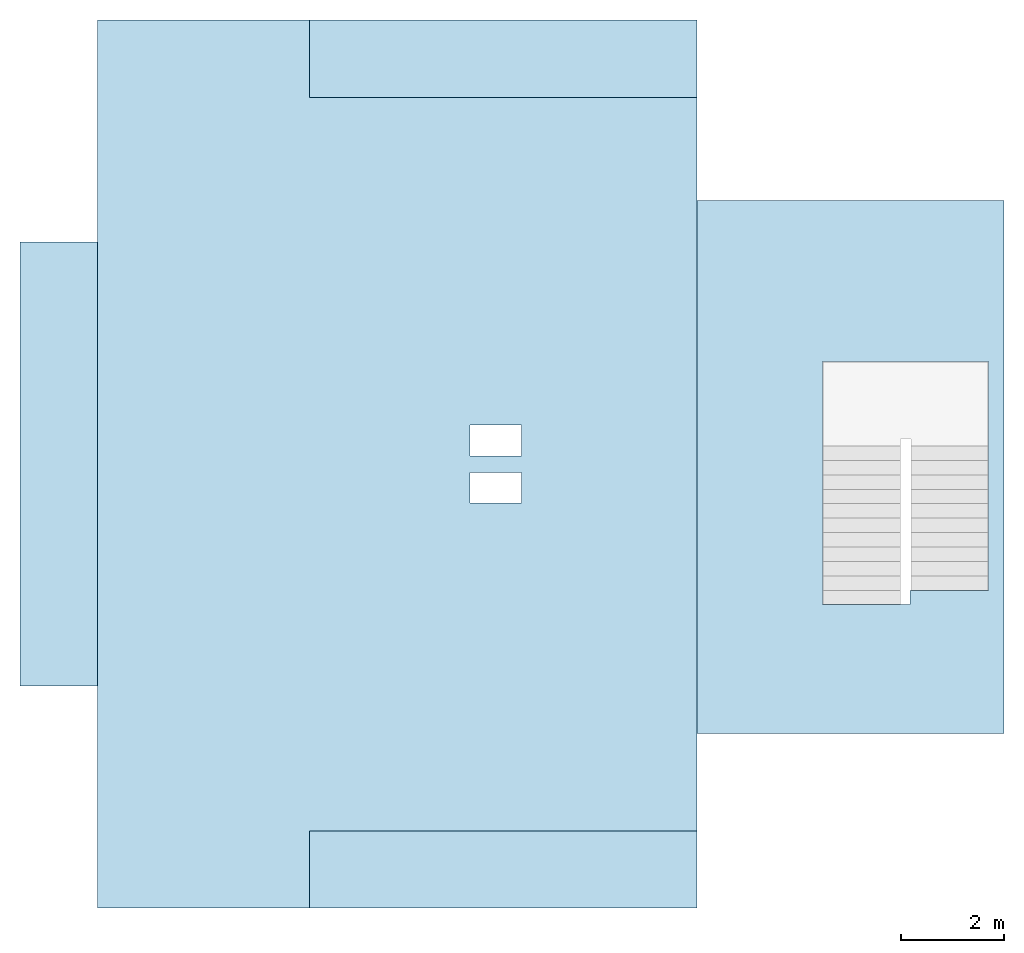
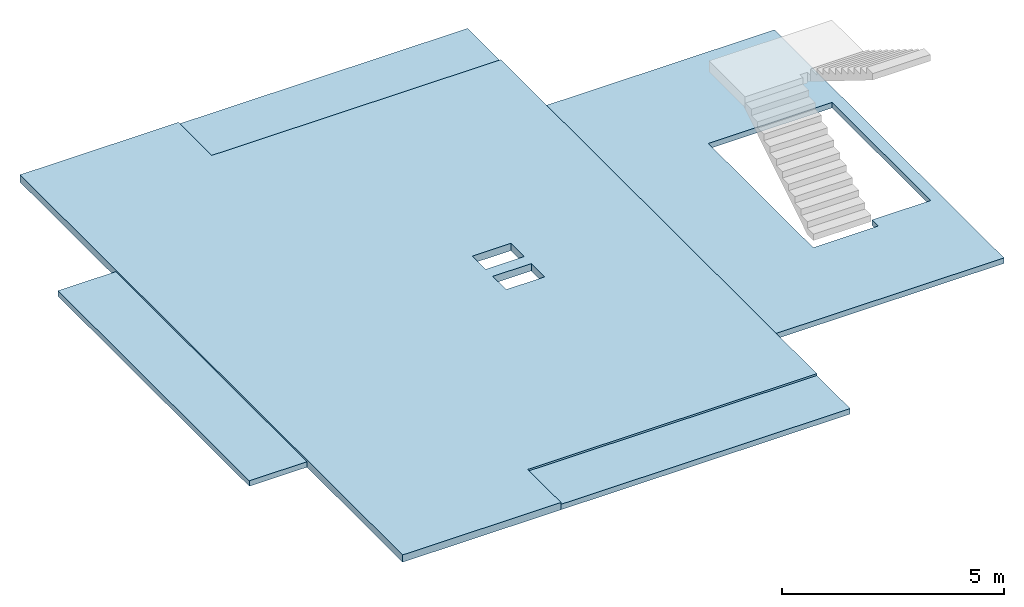
# One storey, part 1 of 2: 5 slabs.
"""IFC2X3 building model written with IfcOpenShell, lengths in millimetres."""

import ifcopenshell
import ifcopenshell.guid

model = None  # the IFC model being written
_history = None  # IfcOwnerHistory: only IFC2X3 demands one
_inside = {}  # id of a spatial element -> (the spatial element, [elements in it])
_under = {}  # id of a project, library or spatial element -> (it, [spatial elements below it])
_declared = {}  # id of a project -> (the project, [libraries it declares])
_typed = {}  # id of a type object -> (the type object, [elements of that type])
_made_of = {}  # id of a material, layer set ... -> (it, [elements and type objects made of it])


def new_model(schema):
    """Start an empty IFC model of exactly this schema.

    Asked for "IFC4X3", IfcOpenShell would pick the latest addendum, in which some entities
    have other attributes; the version numbers below select the first issue.
    IFC2X3 requires an IfcOwnerHistory on every rooted entity: one is made here for all.
    """
    global model, _history
    if schema == "IFC4X3":
        model = ifcopenshell.file(schema_version=(4, 3, 0, 0))
    else:
        model = ifcopenshell.file(schema=schema)
    _inside.clear()
    _under.clear()
    _declared.clear()
    _typed.clear()
    _made_of.clear()
    _history = None
    if model.schema == "IFC2X3":
        org = make("IfcOrganization", Name="unknown")
        user = make(
            "IfcPersonAndOrganization",
            ThePerson=make("IfcPerson", FamilyName="unknown"),
            TheOrganization=org,
        )
        app = make(
            "IfcApplication",
            ApplicationDeveloper=org,
            Version="unknown",
            ApplicationFullName="unknown",
            ApplicationIdentifier="unknown",
        )
        _history = make(
            "IfcOwnerHistory",
            OwningUser=user,
            OwningApplication=app,
            ChangeAction="ADDED",
            CreationDate=0,
        )
    return model


def make(cls, **values):
    """One entity of the class cls with the attributes given. An attribute that is None is left unset."""
    return model.create_entity(
        cls, **{name: value for name, value in values.items() if value is not None}
    )


def entity(cls, *values):
    """Any entity or typed value of the class cls, its attributes in the order of the schema. None: left unset."""
    e = model.create_entity(cls)
    for i, value in enumerate(values):
        if value is not None:
            e[i] = value
    return e


def rooted(cls, **values):
    """An entity with a GlobalId (a new one), such as an element, a storey or a relation."""
    return make(cls, GlobalId=ifcopenshell.guid.new(), OwnerHistory=_history, **values)


def si_unit(unit_type, name, prefix=None):
    """IfcSIUnit, for example si_unit("LENGTHUNIT", "METRE", prefix="MILLI")."""
    return make("IfcSIUnit", UnitType=unit_type, Prefix=prefix, Name=name)


def converted_unit(unit_type, name, factor, base, dimensions=None, offset=None):
    """IfcConversionBasedUnit, such as the inch: factor (a typed value) times the base unit."""
    return make(
        "IfcConversionBasedUnit"
        if offset is None
        else "IfcConversionBasedUnitWithOffset",
        ConversionOffset=offset,
        Dimensions=None
        if dimensions is None
        else entity("IfcDimensionalExponents", *dimensions),
        UnitType=unit_type,
        Name=name,
        ConversionFactor=make(
            "IfcMeasureWithUnit", ValueComponent=factor, UnitComponent=base
        ),
    )


def derived_unit(unit_type, elements):
    """IfcDerivedUnit: a product of units, each with its exponent."""
    return make(
        "IfcDerivedUnit",
        Elements=[
            make("IfcDerivedUnitElement", Unit=unit, Exponent=power)
            for unit, power in elements
        ],
        UnitType=unit_type,
    )


def assignment(units):
    """IfcUnitAssignment: the units of a project."""
    return None if units is None else make("IfcUnitAssignment", Units=units)


def point(xyz):
    """IfcCartesianPoint."""
    return None if xyz is None else make("IfcCartesianPoint", Coordinates=xyz)


def direction(xyz):
    """IfcDirection."""
    return None if xyz is None else make("IfcDirection", DirectionRatios=xyz)


def frame(location, z_axis=None, x_axis=None):
    """IfcAxis2Placement3D, a coordinate frame: its origin and axes. An axis left out is left unset."""
    return make(
        "IfcAxis2Placement3D",
        Location=point(location),
        Axis=direction(z_axis),
        RefDirection=direction(x_axis),
    )


def frame_2d(location, x_axis=None):
    """IfcAxis2Placement2D, a coordinate frame in the plane: its origin and x axis."""
    return make(
        "IfcAxis2Placement2D", Location=point(location), RefDirection=direction(x_axis)
    )


def origin():
    """The frame at (0, 0, 0) with its axes left unset."""
    return frame((0.0, 0.0, 0.0))


def place(relative_to, where):
    """IfcLocalPlacement: puts the frame where relative to a parent placement (None: the world)."""
    return make(
        "IfcLocalPlacement", PlacementRelTo=relative_to, RelativePlacement=where
    )


def context(
    kind, dimensions, precision=None, world=None, true_north=None, identifier=None
):
    """IfcGeometricRepresentationContext, for example the 3D "Model" context."""
    return make(
        "IfcGeometricRepresentationContext",
        ContextIdentifier=identifier,
        ContextType=kind,
        CoordinateSpaceDimension=dimensions,
        Precision=precision,
        WorldCoordinateSystem=world,
        TrueNorth=true_north,
    )


def subcontext(parent, identifier, kind, view, scale=None):
    """IfcGeometricRepresentationSubContext, for example "Body" below "Model"."""
    return make(
        "IfcGeometricRepresentationSubContext",
        ContextIdentifier=identifier,
        ContextType=kind,
        ParentContext=parent,
        TargetScale=scale,
        TargetView=view,
    )


def project(units=None, contexts=None):
    """IfcProject with its units and contexts."""
    return rooted(
        "IfcProject",
        Name="project",
        RepresentationContexts=contexts,
        UnitsInContext=assignment(units),
    )


def spatial(cls, under=None, at=None, **own):
    """A site, building, storey or space (cls), placed at a placement, below another one or the project."""
    s = rooted(cls, ObjectPlacement=at, **own)
    if under is not None:
        _under.setdefault(under.id(), (under, []))[1].append(s)
    return s


def polyline(points):
    """IfcPolyline through the points."""
    return make("IfcPolyline", Points=[point(p) for p in points])


def profile(cls, at=None, kind="AREA", **sizes):
    """A parametric profile (cls). Its sizes go by their IFC names, for example OverallWidth=200.0."""
    return make(cls, ProfileType=kind, Position=at, **sizes)


def rectangle(**sizes):
    """IfcRectangleProfileDef."""
    return profile("IfcRectangleProfileDef", **sizes)


def outline(outer, holes=None, kind="AREA"):
    """IfcArbitraryClosedProfileDef: a profile drawn as a closed curve; with holes, ...WithVoids."""
    if holes is None:
        return make("IfcArbitraryClosedProfileDef", ProfileType=kind, OuterCurve=outer)
    return make(
        "IfcArbitraryProfileDefWithVoids",
        ProfileType=kind,
        OuterCurve=outer,
        InnerCurves=holes,
    )


def extrude(swept, where, along, depth):
    """IfcExtrudedAreaSolid: the profile swept, set in the frame where, extruded along a direction by depth."""
    return make(
        "IfcExtrudedAreaSolid",
        SweptArea=swept,
        Position=where,
        ExtrudedDirection=direction(along),
        Depth=depth,
    )


def shape(context_of_items, identifier, shape_type, items):
    """IfcShapeRepresentation: the items that make up one representation, for example the "Body"."""
    return make(
        "IfcShapeRepresentation",
        ContextOfItems=context_of_items,
        RepresentationIdentifier=identifier,
        RepresentationType=shape_type,
        Items=items,
    )


def material(Name=None, Category=None):
    """IfcMaterial."""
    return make("IfcMaterial", Name=Name, Category=Category)


def layer(
    of_material, thickness, ventilated=None, Name=None, Category=None, Priority=None
):
    """IfcMaterialLayer: one layer of a wall or slab, of a material (None: an air gap)."""
    return make(
        "IfcMaterialLayer",
        Material=of_material,
        LayerThickness=thickness,
        IsVentilated=ventilated,
        Name=Name,
        Category=Category,
        Priority=Priority,
    )


def layer_set(layers, Name=None):
    """IfcMaterialLayerSet."""
    return make("IfcMaterialLayerSet", MaterialLayers=layers, LayerSetName=Name)


def layer_usage(for_layer_set, set_direction, sense, offset, extent=None):
    """IfcMaterialLayerSetUsage: how a layer set lies in its element."""
    return make(
        "IfcMaterialLayerSetUsage",
        ForLayerSet=for_layer_set,
        LayerSetDirection=set_direction,
        DirectionSense=sense,
        OffsetFromReferenceLine=offset,
        ReferenceExtent=extent,
    )


def made_of(thing, what):
    """Note that an element or type object is made of a material, layer set ...; save() writes the relation."""
    if what is not None:
        _made_of.setdefault(what.id(), (what, []))[1].append(thing)
    return thing


def type_object(cls, material=None, **own):
    """A type object (cls), such as IfcWallType, which elements share."""
    return made_of(rooted(cls, **own), material)


def element(
    cls,
    number,
    at=None,
    inside=None,
    cuts=None,
    type_object=None,
    material=None,
    context=None,
    identifier="Body",
    shape_type=None,
    held_by="IfcProductDefinitionShape",
    body=None,
    shapes=None,
    **own,
):
    """One element of the class cls, such as IfcWall. Its Tag is "e" and its number.

    at: its placement. inside: the storey or other place that contains it. cuts: it is an
    opening in that element (IfcRelVoidsElement). A single representation is given by context,
    identifier, shape_type and body (its items); several are given by shapes. held_by: the class
    of the entity that holds the representations. save() writes the other relations.
    """
    e = rooted(cls, Tag="e%d" % number, ObjectPlacement=at, **own)
    if body is not None:
        shapes = [shape(context, identifier, shape_type, body)]
    if shapes is not None:
        e.Representation = make(held_by, Representations=shapes)
    if inside is not None:
        _inside.setdefault(inside.id(), (inside, []))[1].append(e)
    if cuts is not None:
        rooted(
            "IfcRelVoidsElement", RelatingBuildingElement=cuts, RelatedOpeningElement=e
        )
    if type_object is not None:
        _typed.setdefault(type_object.id(), (type_object, []))[1].append(e)
    return made_of(e, material)


def aggregate(whole, parts):
    """IfcRelAggregates: a whole, such as a stair, and the parts it consists of."""
    return rooted("IfcRelAggregates", RelatingObject=whole, RelatedObjects=parts)


def save(model, path):
    """Write the relations noted so far, then the file.

    IfcRelAggregates (storeys below a building ...), IfcRelContainedInSpatialStructure (elements
    in a storey), IfcRelDefinesByType, IfcRelAssociatesMaterial and IfcRelDeclares: one each for
    every whole, place, type object, material and project.
    """
    for whole, parts in _under.values():
        aggregate(whole, parts)
    for where, things in _inside.values():
        rooted(
            "IfcRelContainedInSpatialStructure",
            RelatedElements=things,
            RelatingStructure=where,
        )
    for kind, things in _typed.values():
        rooted("IfcRelDefinesByType", RelatedObjects=things, RelatingType=kind)
    for what, things in _made_of.values():
        rooted("IfcRelAssociatesMaterial", RelatedObjects=things, RelatingMaterial=what)
    for by, libraries in _declared.values():
        rooted("IfcRelDeclares", RelatingContext=by, RelatedDefinitions=libraries)
    model.write(path)


model = new_model("IFC2X3")

# Units and contexts
model_context = context("Model", 3, precision=0.01, world=origin(), true_north=direction((6.12303176911189e-17, 1.0)))
body_context = subcontext(model_context, "Body", "Model", "MODEL_VIEW")
ifc_project = project(units=[si_unit("LENGTHUNIT", "METRE", prefix="MILLI"), si_unit("AREAUNIT", "SQUARE_METRE"), si_unit("VOLUMEUNIT", "CUBIC_METRE"), converted_unit("PLANEANGLEUNIT", "DEGREE", entity("IfcRatioMeasure", 0.0174532925199433), si_unit("PLANEANGLEUNIT", "RADIAN"), dimensions=[0, 0, 0, 0, 0, 0, 0]), si_unit("MASSUNIT", "GRAM", prefix="KILO"), derived_unit("MASSDENSITYUNIT", [(si_unit("MASSUNIT", "GRAM", prefix="KILO"), 1), (si_unit("LENGTHUNIT", "METRE"), -3)]), si_unit("TIMEUNIT", "SECOND"), si_unit("FREQUENCYUNIT", "HERTZ"), si_unit("THERMODYNAMICTEMPERATUREUNIT", "DEGREE_CELSIUS"), derived_unit("THERMALTRANSMITTANCEUNIT", [(si_unit("MASSUNIT", "GRAM", prefix="KILO"), 1), (si_unit("THERMODYNAMICTEMPERATUREUNIT", "KELVIN"), -1), (si_unit("TIMEUNIT", "SECOND"), -3)]), derived_unit("VOLUMETRICFLOWRATEUNIT", [(si_unit("LENGTHUNIT", "METRE"), 3), (si_unit("TIMEUNIT", "SECOND"), -1)]), si_unit("ELECTRICCURRENTUNIT", "AMPERE"), si_unit("ELECTRICVOLTAGEUNIT", "VOLT"), si_unit("POWERUNIT", "WATT"), si_unit("FORCEUNIT", "NEWTON", prefix="KILO"), si_unit("ILLUMINANCEUNIT", "LUX"), si_unit("LUMINOUSFLUXUNIT", "LUMEN"), si_unit("LUMINOUSINTENSITYUNIT", "CANDELA"), derived_unit("USERDEFINED", [(si_unit("MASSUNIT", "GRAM", prefix="KILO"), -1), (si_unit("LENGTHUNIT", "METRE"), -2), (si_unit("TIMEUNIT", "SECOND"), 3), (si_unit("LUMINOUSFLUXUNIT", "LUMEN"), 1)]), derived_unit("LINEARVELOCITYUNIT", [(si_unit("LENGTHUNIT", "METRE"), 1), (si_unit("TIMEUNIT", "SECOND"), -1)]), si_unit("PRESSUREUNIT", "PASCAL"), derived_unit("USERDEFINED", [(si_unit("LENGTHUNIT", "METRE"), -2), (si_unit("MASSUNIT", "GRAM", prefix="KILO"), 1), (si_unit("TIMEUNIT", "SECOND"), -2)])], contexts=[model_context])

# Site, building, storey
site_placement = place(None, origin())
site = spatial("IfcSite", under=ifc_project, at=site_placement, CompositionType="ELEMENT")
building_placement = place(site_placement, origin())
building = spatial("IfcBuilding", under=site, at=building_placement, CompositionType="ELEMENT")
storey_placement = place(building_placement, frame((0.0, 0.0, 4000.0)))
storey = spatial("IfcBuildingStorey", under=building, at=storey_placement, Name="01 Level", CompositionType="ELEMENT", Elevation=4000.0)

# Slabs
ifc_material = material(Name="02_C40/50")
ifc_layer_1 = layer(ifc_material, 200.0)
ifc_layer_set_1 = layer_set([ifc_layer_1], Name="Floor:200mm")
ifc_layer_usage_1 = layer_usage(ifc_layer_set_1, "AXIS3", "POSITIVE", 0.0)
slab_type_1 = type_object("IfcSlabType", Name="Floor:200mm", PredefinedType="FLOOR", material=ifc_layer_set_1)
slab_1_placement = place(storey_placement, origin())
element("IfcSlab", 1, at=slab_1_placement, inside=storey, type_object=slab_type_1, material=ifc_layer_usage_1, Name="Floor:200mm", ObjectType="Floor:200mm", PredefinedType="FLOOR", context=body_context, shape_type="SweptSolid", body=[
    extrude(outline(polyline([(-9344.20846054567, -5469.5), (-9034.20846054567, -5469.5), (-5034.20846054565, -5469.50000000001), (3585.79153945433, -5469.50000000002), (7585.79153945434, -5469.50000000003), (7895.79153945434, -5469.50000000003), (7895.79153945434, -1659.50000000001), (7895.79153945434, -1349.50000000001), (6525.79153945435, -1349.50000000001), (6395.79153945435, -1349.50000000001), (6395.79153945435, 5860.49999999999), (6395.79153945435, 6170.49999999999), (6085.79153945434, 6170.49999999999), (4505.37614491075, 6170.49999999999), (-5839.62385508921, 6170.50000000001), (-7534.20846054555, 6170.50000000001), (-7844.2084605456, 6170.50000000001), (-7844.20846054564, -1349.49999999997), (-9344.20846054564, -1349.49999999996), (-9344.20846054564, -1659.49999999996), (-9344.20846054567, -5469.5)]), holes=[polyline([(-564.208460545644, 2760.50000000002), (35.7915394543671, 2760.50000000002), (35.7915394543671, 1760.5), (-564.208460545644, 1760.5), (-564.208460545644, 2760.50000000002)]), polyline([(-1484.20846054563, 2760.50000000001), (-884.208460545614, 2760.50000000001), (-884.208460545614, 1760.50000000001), (-1484.20846054563, 1760.50000000001), (-1484.20846054563, 2760.50000000001)])]), frame((22642.9900708518, -69555.4480456856, -340.0), z_axis=(0.0, 0.0, 1.0), x_axis=(0.0, -1.0, 0.0)), (0.0, 0.0, 1.0), 200.0),
])
ifc_layer_2 = layer(ifc_material, 150.0)
ifc_layer_set_2 = layer_set([ifc_layer_2], Name="Floor:150mm")
ifc_layer_usage_2 = layer_usage(ifc_layer_set_2, "AXIS3", "POSITIVE", 0.0)
slab_type_2 = type_object("IfcSlabType", Name="Floor:150mm", PredefinedType="FLOOR")
slab_2_placement = place(storey_placement, frame((15673.4900708517, -77451.2395851399, -340.0)))
element("IfcSlab", 2, at=slab_2_placement, inside=storey, type_object=slab_type_2, material=ifc_layer_usage_2, Name="Floor:150mm", ObjectType="Floor:150mm", PredefinedType="FLOOR", context=body_context, shape_type="SweptSolid", body=[
    extrude(rectangle(XDim=7520.0, YDim=1499.99999999999, at=frame_2d((-2810.0, -7870.0), x_axis=(-1.0, 0.0))), frame((6570.0, 8620.0, 150.0), z_axis=(0.0, 0.0, -1.0), x_axis=(-1.0, 0.0, 0.0)), (0.0, 0.0, 1.0), 150.0),
])
slab_type_3 = type_object("IfcSlabType", Name="Floor:150mm", PredefinedType="FLOOR")
slab_3_placement = place(storey_placement, frame((15673.4900708517, -77451.2395851399, -340.0)))
element("IfcSlab", 3, at=slab_3_placement, inside=storey, type_object=slab_type_3, material=ifc_layer_usage_2, Name="Floor:150mm:2", ObjectType="Floor:150mm", PredefinedType="FLOOR", context=body_context, shape_type="SweptSolid", body=[
    extrude(rectangle(XDim=8619.99999999999, YDim=1500.00000000002, at=frame_2d((5820.0, 0.0), x_axis=(0.0, 1.0))), frame((6570.0, 8620.0, 150.0), z_axis=(0.0, 0.0, -1.0), x_axis=(-1.0, 0.0, 0.0)), (0.0, 0.0, 1.0), 150.0),
])
slab_type_4 = type_object("IfcSlabType", Name="Floor:150mm", PredefinedType="FLOOR", material=ifc_layer_set_2)
slab_4_placement = place(storey_placement, frame((15673.4900708517, -77451.2395851399, -340.0)))
element("IfcSlab", 4, at=slab_4_placement, inside=storey, type_object=slab_type_4, material=ifc_layer_usage_2, Name="Floor:150mm:3", ObjectType="Floor:150mm", PredefinedType="FLOOR", context=body_context, shape_type="SweptSolid", body=[
    extrude(rectangle(XDim=1500.0, YDim=7520.0, at=frame_2d((-2810.0, 7870.0), x_axis=(0.0, 1.0))), frame((6570.0, 8620.0, 150.0), z_axis=(0.0, 0.0, -1.0), x_axis=(-1.0, 0.0, 0.0)), (0.0, 0.0, 1.0), 150.0),
])
ifc_layer_usage_3 = layer_usage(ifc_layer_set_2, "AXIS3", "POSITIVE", 0.0)
slab_type_5 = type_object("IfcSlabType", Name="Floor:150mm", PredefinedType="FLOOR", material=ifc_layer_set_2)
slab_5_placement = place(storey_placement, origin())
element("IfcSlab", 5, at=slab_5_placement, inside=storey, type_object=slab_type_5, material=ifc_layer_usage_3, Name="Floor:150mm", ObjectType="Floor:150mm", PredefinedType="FLOOR", context=body_context, shape_type="SweptSolid", body=[
    extrude(outline(polyline([(-2839.0909090909, -4473.63636363636), (-2529.0909090909, -4473.63636363636), (670.90909090908, -4473.63636363636), (990.909090909081, -4473.63636363636), (2990.9090909091, -4473.63636363636), (3120.90909090909, -4473.63636363636), (3120.90909090909, 5871.3636363636), (2990.90909090909, 5871.3636363636), (-2839.0909090909, 5871.3636363636), (-2839.0909090909, 5856.36363636359), (-2839.0909090909, 3371.3636363636), (-2839.0909090909, -4473.63636363636)]), holes=[polyline([(-1013.27243941174, 3371.3636363636), (670.909090909106, 3371.3636363636), (680.909090909086, 3371.3636363636), (680.909090909086, -1353.63636363636), (670.909090909088, -1353.63636363636), (-2529.09090909089, -1353.63636363636), (-2539.09090909087, -1353.63636363636), (-2539.09090909087, 3091.36363636361), (-2529.09090909087, 3091.36363636361), (-1013.27243941174, 3091.36363636361), (-1013.27243941174, 3371.3636363636)])]), frame((31934.3991617609, -68189.4605542327, -340.0), z_axis=(0.0, 0.0, 1.0), x_axis=(-1.0, 0.0, 0.0)), (0.0, 0.0, 1.0), 150.0),
])

save(model, "model.ifc")
